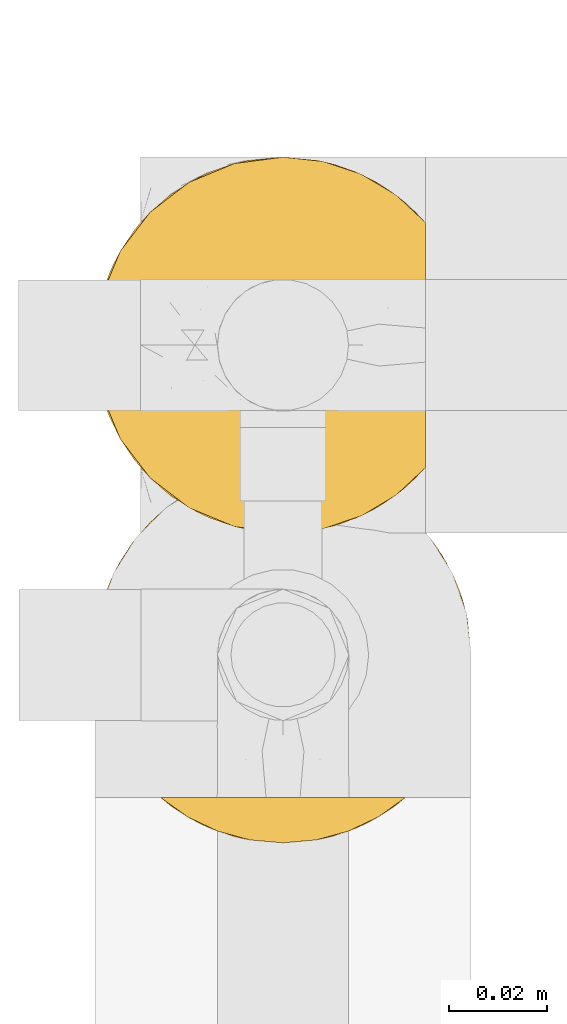
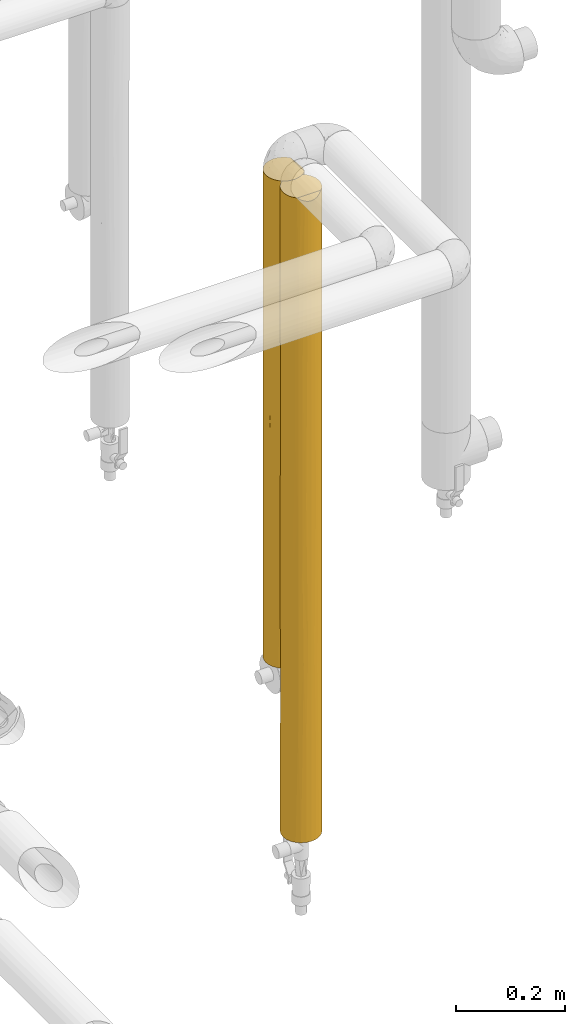
# One storey, part 30 of 827: 2 coverings.
"""IFC2X3 building model written with IfcOpenShell, lengths in millimetres."""

import ifcopenshell
import ifcopenshell.guid

model = None  # the IFC model being written
_history = None  # IfcOwnerHistory: only IFC2X3 demands one
_inside = {}  # id of a spatial element -> (the spatial element, [elements in it])
_under = {}  # id of a project, library or spatial element -> (it, [spatial elements below it])
_declared = {}  # id of a project -> (the project, [libraries it declares])
_typed = {}  # id of a type object -> (the type object, [elements of that type])
_made_of = {}  # id of a material, layer set ... -> (it, [elements and type objects made of it])


def new_model(schema):
    """Start an empty IFC model of exactly this schema.

    Asked for "IFC4X3", IfcOpenShell would pick the latest addendum, in which some entities
    have other attributes; the version numbers below select the first issue.
    IFC2X3 requires an IfcOwnerHistory on every rooted entity: one is made here for all.
    """
    global model, _history
    if schema == "IFC4X3":
        model = ifcopenshell.file(schema_version=(4, 3, 0, 0))
    else:
        model = ifcopenshell.file(schema=schema)
    _inside.clear()
    _under.clear()
    _declared.clear()
    _typed.clear()
    _made_of.clear()
    _history = None
    if model.schema == "IFC2X3":
        org = make("IfcOrganization", Name="unknown")
        user = make(
            "IfcPersonAndOrganization",
            ThePerson=make("IfcPerson", FamilyName="unknown"),
            TheOrganization=org,
        )
        app = make(
            "IfcApplication",
            ApplicationDeveloper=org,
            Version="unknown",
            ApplicationFullName="unknown",
            ApplicationIdentifier="unknown",
        )
        _history = make(
            "IfcOwnerHistory",
            OwningUser=user,
            OwningApplication=app,
            ChangeAction="ADDED",
            CreationDate=0,
        )
    return model


def make(cls, **values):
    """One entity of the class cls with the attributes given. An attribute that is None is left unset."""
    return model.create_entity(
        cls, **{name: value for name, value in values.items() if value is not None}
    )


def entity(cls, *values):
    """Any entity or typed value of the class cls, its attributes in the order of the schema. None: left unset."""
    e = model.create_entity(cls)
    for i, value in enumerate(values):
        if value is not None:
            e[i] = value
    return e


def rooted(cls, **values):
    """An entity with a GlobalId (a new one), such as an element, a storey or a relation."""
    return make(cls, GlobalId=ifcopenshell.guid.new(), OwnerHistory=_history, **values)


def si_unit(unit_type, name, prefix=None):
    """IfcSIUnit, for example si_unit("LENGTHUNIT", "METRE", prefix="MILLI")."""
    return make("IfcSIUnit", UnitType=unit_type, Prefix=prefix, Name=name)


def converted_unit(unit_type, name, factor, base, dimensions=None, offset=None):
    """IfcConversionBasedUnit, such as the inch: factor (a typed value) times the base unit."""
    return make(
        "IfcConversionBasedUnit"
        if offset is None
        else "IfcConversionBasedUnitWithOffset",
        ConversionOffset=offset,
        Dimensions=None
        if dimensions is None
        else entity("IfcDimensionalExponents", *dimensions),
        UnitType=unit_type,
        Name=name,
        ConversionFactor=make(
            "IfcMeasureWithUnit", ValueComponent=factor, UnitComponent=base
        ),
    )


def derived_unit(unit_type, elements):
    """IfcDerivedUnit: a product of units, each with its exponent."""
    return make(
        "IfcDerivedUnit",
        Elements=[
            make("IfcDerivedUnitElement", Unit=unit, Exponent=power)
            for unit, power in elements
        ],
        UnitType=unit_type,
    )


def assignment(units):
    """IfcUnitAssignment: the units of a project."""
    return None if units is None else make("IfcUnitAssignment", Units=units)


def point(xyz):
    """IfcCartesianPoint."""
    return None if xyz is None else make("IfcCartesianPoint", Coordinates=xyz)


def direction(xyz):
    """IfcDirection."""
    return None if xyz is None else make("IfcDirection", DirectionRatios=xyz)


def frame(location, z_axis=None, x_axis=None):
    """IfcAxis2Placement3D, a coordinate frame: its origin and axes. An axis left out is left unset."""
    return make(
        "IfcAxis2Placement3D",
        Location=point(location),
        Axis=direction(z_axis),
        RefDirection=direction(x_axis),
    )


def origin():
    """The frame at (0, 0, 0) with its axes left unset."""
    return frame((0.0, 0.0, 0.0))


def place(relative_to, where):
    """IfcLocalPlacement: puts the frame where relative to a parent placement (None: the world)."""
    return make(
        "IfcLocalPlacement", PlacementRelTo=relative_to, RelativePlacement=where
    )


def context(
    kind, dimensions, precision=None, world=None, true_north=None, identifier=None
):
    """IfcGeometricRepresentationContext, for example the 3D "Model" context."""
    return make(
        "IfcGeometricRepresentationContext",
        ContextIdentifier=identifier,
        ContextType=kind,
        CoordinateSpaceDimension=dimensions,
        Precision=precision,
        WorldCoordinateSystem=world,
        TrueNorth=true_north,
    )


def subcontext(parent, identifier, kind, view, scale=None):
    """IfcGeometricRepresentationSubContext, for example "Body" below "Model"."""
    return make(
        "IfcGeometricRepresentationSubContext",
        ContextIdentifier=identifier,
        ContextType=kind,
        ParentContext=parent,
        TargetScale=scale,
        TargetView=view,
    )


def project(units=None, contexts=None):
    """IfcProject with its units and contexts."""
    return rooted(
        "IfcProject",
        Name="project",
        RepresentationContexts=contexts,
        UnitsInContext=assignment(units),
    )


def spatial(cls, under=None, at=None, **own):
    """A site, building, storey or space (cls), placed at a placement, below another one or the project."""
    s = rooted(cls, ObjectPlacement=at, **own)
    if under is not None:
        _under.setdefault(under.id(), (under, []))[1].append(s)
    return s


def faces_of(points, faces, orient=None, outer=None):
    """IfcFace entities. A face is a list of loops; a loop is a list of indices into points, from 0.

    orient and outer hold one flag for each loop. By default every Orientation is true, the
    first loop of a face is its IfcFaceOuterBound and the others are IfcFaceBound.
    """
    made = []
    for i, loops in enumerate(faces):
        bounds = []
        for j, loop in enumerate(loops):
            is_outer = j == 0 if outer is None else outer[i][j]
            bounds.append(
                make(
                    "IfcFaceOuterBound" if is_outer else "IfcFaceBound",
                    Bound=make("IfcPolyLoop", Polygon=[points[k] for k in loop]),
                    Orientation=True if orient is None else orient[i][j],
                )
            )
        made.append(make("IfcFace", Bounds=bounds))
    return made


def faceted_brep(points, faces, orient=None, outer=None, voids=None):
    """IfcFacetedBrep: a solid bounded by flat faces; with voids (closed shells), ...WithVoids."""
    shared = [point(p) for p in points]
    hull = make("IfcClosedShell", CfsFaces=faces_of(shared, faces, orient, outer))
    if voids is None:
        return make("IfcFacetedBrep", Outer=hull)
    return make(
        "IfcFacetedBrepWithVoids",
        Outer=hull,
        Voids=[
            make(cls, CfsFaces=faces_of(shared, fs, o, b)) for cls, fs, o, b in voids
        ],
    )


def shape(context_of_items, identifier, shape_type, items):
    """IfcShapeRepresentation: the items that make up one representation, for example the "Body"."""
    return make(
        "IfcShapeRepresentation",
        ContextOfItems=context_of_items,
        RepresentationIdentifier=identifier,
        RepresentationType=shape_type,
        Items=items,
    )


def made_of(thing, what):
    """Note that an element or type object is made of a material, layer set ...; save() writes the relation."""
    if what is not None:
        _made_of.setdefault(what.id(), (what, []))[1].append(thing)
    return thing


def element(
    cls,
    number,
    at=None,
    inside=None,
    cuts=None,
    type_object=None,
    material=None,
    context=None,
    identifier="Body",
    shape_type=None,
    held_by="IfcProductDefinitionShape",
    body=None,
    shapes=None,
    **own,
):
    """One element of the class cls, such as IfcWall. Its Tag is "e" and its number.

    at: its placement. inside: the storey or other place that contains it. cuts: it is an
    opening in that element (IfcRelVoidsElement). A single representation is given by context,
    identifier, shape_type and body (its items); several are given by shapes. held_by: the class
    of the entity that holds the representations. save() writes the other relations.
    """
    e = rooted(cls, Tag="e%d" % number, ObjectPlacement=at, **own)
    if body is not None:
        shapes = [shape(context, identifier, shape_type, body)]
    if shapes is not None:
        e.Representation = make(held_by, Representations=shapes)
    if inside is not None:
        _inside.setdefault(inside.id(), (inside, []))[1].append(e)
    if cuts is not None:
        rooted(
            "IfcRelVoidsElement", RelatingBuildingElement=cuts, RelatedOpeningElement=e
        )
    if type_object is not None:
        _typed.setdefault(type_object.id(), (type_object, []))[1].append(e)
    return made_of(e, material)


def aggregate(whole, parts):
    """IfcRelAggregates: a whole, such as a stair, and the parts it consists of."""
    return rooted("IfcRelAggregates", RelatingObject=whole, RelatedObjects=parts)


def save(model, path):
    """Write the relations noted so far, then the file.

    IfcRelAggregates (storeys below a building ...), IfcRelContainedInSpatialStructure (elements
    in a storey), IfcRelDefinesByType, IfcRelAssociatesMaterial and IfcRelDeclares: one each for
    every whole, place, type object, material and project.
    """
    for whole, parts in _under.values():
        aggregate(whole, parts)
    for where, things in _inside.values():
        rooted(
            "IfcRelContainedInSpatialStructure",
            RelatedElements=things,
            RelatingStructure=where,
        )
    for kind, things in _typed.values():
        rooted("IfcRelDefinesByType", RelatedObjects=things, RelatingType=kind)
    for what, things in _made_of.values():
        rooted("IfcRelAssociatesMaterial", RelatedObjects=things, RelatingMaterial=what)
    for by, libraries in _declared.values():
        rooted("IfcRelDeclares", RelatingContext=by, RelatedDefinitions=libraries)
    model.write(path)


model = new_model("IFC2X3")

# Units and contexts
model_context = context("Model", 3, precision=0.01, world=origin(), true_north=direction((6.12303176911189e-17, 1.0)))
body_context = subcontext(model_context, "Body", "Model", "MODEL_VIEW")
ifc_project = project(units=[si_unit("LENGTHUNIT", "METRE", prefix="MILLI"), si_unit("AREAUNIT", "SQUARE_METRE"), si_unit("VOLUMEUNIT", "CUBIC_METRE"), converted_unit("PLANEANGLEUNIT", "DEGREE", entity("IfcRatioMeasure", 0.0174532925199433), si_unit("PLANEANGLEUNIT", "RADIAN"), dimensions=[0, 0, 0, 0, 0, 0, 0]), si_unit("MASSUNIT", "GRAM", prefix="KILO"), derived_unit("MASSDENSITYUNIT", [(si_unit("MASSUNIT", "GRAM", prefix="KILO"), 1), (si_unit("LENGTHUNIT", "METRE"), -3)]), derived_unit("MOMENTOFINERTIAUNIT", [(si_unit("LENGTHUNIT", "METRE"), 4)]), si_unit("TIMEUNIT", "SECOND"), si_unit("FREQUENCYUNIT", "HERTZ"), si_unit("THERMODYNAMICTEMPERATUREUNIT", "DEGREE_CELSIUS"), derived_unit("THERMALTRANSMITTANCEUNIT", [(si_unit("MASSUNIT", "GRAM", prefix="KILO"), 1), (si_unit("THERMODYNAMICTEMPERATUREUNIT", "KELVIN"), -1), (si_unit("TIMEUNIT", "SECOND"), -3)]), derived_unit("VOLUMETRICFLOWRATEUNIT", [(si_unit("LENGTHUNIT", "METRE"), 3), (si_unit("TIMEUNIT", "SECOND"), -1)]), derived_unit("MASSFLOWRATEUNIT", [(si_unit("MASSUNIT", "GRAM", prefix="KILO"), 1), (si_unit("TIMEUNIT", "SECOND"), -1)]), derived_unit("ROTATIONALFREQUENCYUNIT", [(si_unit("TIMEUNIT", "SECOND"), -1)]), si_unit("ELECTRICCURRENTUNIT", "AMPERE"), si_unit("ELECTRICVOLTAGEUNIT", "VOLT"), si_unit("POWERUNIT", "WATT"), si_unit("FORCEUNIT", "NEWTON", prefix="KILO"), si_unit("ILLUMINANCEUNIT", "LUX"), si_unit("LUMINOUSFLUXUNIT", "LUMEN"), si_unit("LUMINOUSINTENSITYUNIT", "CANDELA"), derived_unit("USERDEFINED", [(si_unit("MASSUNIT", "GRAM", prefix="KILO"), -1), (si_unit("LENGTHUNIT", "METRE"), -2), (si_unit("TIMEUNIT", "SECOND"), 3), (si_unit("LUMINOUSFLUXUNIT", "LUMEN"), 1)]), derived_unit("LINEARVELOCITYUNIT", [(si_unit("LENGTHUNIT", "METRE"), 1), (si_unit("TIMEUNIT", "SECOND"), -1)]), si_unit("PRESSUREUNIT", "PASCAL"), derived_unit("USERDEFINED", [(si_unit("LENGTHUNIT", "METRE"), -2), (si_unit("MASSUNIT", "GRAM", prefix="KILO"), 1), (si_unit("TIMEUNIT", "SECOND"), -2)]), derived_unit("LINEARFORCEUNIT", [(si_unit("MASSUNIT", "GRAM", prefix="KILO"), 1), (si_unit("LENGTHUNIT", "METRE"), 1), (si_unit("TIMEUNIT", "SECOND"), -2), (si_unit("LENGTHUNIT", "METRE"), -1)]), derived_unit("PLANARFORCEUNIT", [(si_unit("MASSUNIT", "GRAM", prefix="KILO"), 1), (si_unit("LENGTHUNIT", "METRE"), 1), (si_unit("TIMEUNIT", "SECOND"), -2), (si_unit("LENGTHUNIT", "METRE"), -2)])], contexts=[model_context])

# Site, building, storey
site_placement = place(None, origin())
site = spatial("IfcSite", under=ifc_project, at=site_placement, CompositionType="ELEMENT")
building_placement = place(site_placement, origin())
building = spatial("IfcBuilding", under=site, at=building_placement, CompositionType="ELEMENT")
storey_placement = place(building_placement, frame((0.0, 0.0, 28200.0)))
storey = spatial("IfcBuildingStorey", under=building, at=storey_placement, Name="08", CompositionType="ELEMENT", Elevation=28200.0)

# Coverings
covering_1_placement = place(storey_placement, frame((18846.14, 12179.52, 779.1)))
element("IfcCovering", 1, at=covering_1_placement, inside=storey, Name=":ADSK_", ObjectType=":ADSK_", PredefinedType="INSULATION", context=body_context, shape_type="Brep", body=[
    faceted_brep([(63.08, 9.31, 1091.8), (69.1, 14.94, 1091.8), (69.1, 65.05, 1091.8), (63.08, 70.68, 1091.8), (56.01, 74.9, 1091.8), (48.2, 77.51, 1091.8), (40.0, 78.4, 1091.8), (30.06, 77.09, 1091.8), (20.8, 73.25, 1091.8), (12.84, 67.15, 1091.8), (6.74, 59.2, 1091.8), (2.9, 49.93, 1091.8), (1.6, 40.0, 1091.8), (2.9, 30.06, 1091.8), (6.74, 20.8, 1091.8), (12.84, 12.84, 1091.8), (20.8, 6.74, 1091.8), (30.06, 2.9, 1091.8), (40.0, 1.6, 1091.8), (48.2, 2.48, 1091.8), (56.01, 5.09, 1091.8), (59.2, 6.74, 0.0), (49.93, 2.9, 0.0), (40.0, 1.6, 0.0), (30.06, 2.9, 0.0), (20.8, 6.74, 0.0), (12.84, 12.84, 0.0), (6.74, 20.8, 0.0), (2.9, 30.06, 0.0), (1.6, 40.0, 0.0), (2.9, 49.93, 0.0), (6.74, 59.2, 0.0), (12.84, 67.15, 0.0), (20.8, 73.25, 0.0), (30.06, 77.09, 0.0), (40.0, 78.4, 0.0), (49.93, 77.09, 0.0), (59.2, 73.25, 0.0), (67.15, 67.15, 0.0), (73.25, 59.2, 0.0), (77.09, 49.93, 0.0), (78.4, 40.0, 0.0), (77.09, 30.06, 0.0), (73.25, 20.8, 0.0), (67.15, 12.84, 0.0), (16.62, 70.46, 253.73), (25.3, 75.47, 761.2), (29.25, 76.86, 559.5), (22.76, 74.31, 435.59), (23.2, 74.53, 210.94), (29.5, 76.93, 324.56), (40.0, 78.4, 216.37), (16.62, 70.46, 838.07), (2.28, 47.19, 324.56), (2.23, 46.96, 566.86), (4.52, 54.69, 634.93), (40.0, 78.4, 875.43), (40.0, 78.4, 432.75), (16.62, 70.46, 545.9), (9.53, 63.37, 330.6), (1.6, 40.0, 432.75), (9.53, 63.37, 794.48), (32.96, 77.75, 767.24), (40.0, 78.4, 659.05), (5.29, 56.43, 868.98), (2.6, 48.72, 822.18), (4.52, 54.69, 260.5), (10.67, 64.79, 562.54), (1.6, 40.0, 216.37), (1.6, 40.0, 659.05), (1.6, 40.0, 762.27), (1.6, 40.0, 875.43), (31.28, 2.6, 822.18), (9.53, 16.62, 840.76), (3.54, 27.94, 545.9), (2.28, 32.8, 767.24), (2.28, 32.8, 324.56), (4.52, 25.3, 259.78), (9.53, 16.62, 251.04), (4.52, 25.3, 832.02), (16.62, 9.53, 330.6), (15.2, 10.67, 562.54), (9.53, 16.62, 545.9), (32.8, 2.28, 324.56), (40.0, 1.6, 432.75), (33.03, 2.23, 566.86), (23.57, 5.29, 868.98), (25.3, 4.52, 634.93), (16.62, 9.53, 794.48), (40.0, 1.6, 216.37), (25.3, 4.52, 260.5), (40.0, 1.6, 659.05), (40.0, 1.6, 762.27), (40.0, 1.6, 875.43), (63.37, 9.53, 322.05), (70.46, 16.62, 252.65), (75.47, 25.3, 316.65), (70.98, 17.31, 542.8), (65.6, 11.38, 768.94), (71.1, 17.47, 825.15), (59.66, 7.01, 887.24), (52.17, 3.58, 828.36), (59.66, 7.01, 650.63), (76.74, 28.83, 534.48), (74.39, 22.92, 678.74), (65.29, 11.1, 539.94), (54.69, 4.52, 258.75), (47.2, 2.28, 324.56), (50.14, 2.96, 545.9), (58.19, 6.18, 441.76), (78.4, 40.0, 866.13), (77.79, 33.21, 1083.1), (77.01, 29.79, 775.91), (76.0, 26.63, 1084.9), (78.4, 40.0, 649.75), (73.07, 20.48, 1087.83), (74.87, 23.92, 889.43), (78.4, 40.0, 1082.5), (78.4, 40.0, 432.75), (77.75, 32.96, 324.56), (78.4, 40.0, 216.37), (76.74, 51.16, 534.48), (54.69, 75.47, 328.95), (47.03, 77.75, 324.56), (50.79, 76.85, 532.17), (75.47, 54.69, 316.65), (59.66, 72.98, 650.63), (65.6, 68.61, 768.94), (65.42, 68.77, 530.69), (77.01, 50.2, 775.91), (76.0, 53.36, 1084.9), (77.79, 46.78, 1083.1), (74.39, 57.07, 678.74), (63.37, 70.46, 260.15), (74.7, 56.44, 892.73), (70.46, 63.37, 251.05), (71.1, 62.52, 825.15), (73.07, 59.51, 1087.83), (50.25, 77.0, 767.24), (70.98, 62.68, 542.8), (59.66, 72.98, 887.24), (77.75, 47.03, 324.56)], [[[0, 1, 2, 3, 4, 5, 6, 7, 8, 9, 10, 11, 12, 13, 14, 15, 16, 17, 18, 19, 20]], [[21, 22, 23, 24, 25, 26, 27, 28, 29, 30, 31, 32, 33, 34, 35, 36, 37, 38, 39, 40, 41, 42, 43, 44]], [[33, 32, 45]], [[46, 47, 48]], [[49, 34, 33]], [[50, 51, 34]], [[8, 52, 9]], [[53, 54, 55]], [[51, 35, 34]], [[7, 6, 56]], [[50, 57, 51]], [[47, 57, 50]], [[49, 45, 48]], [[46, 8, 7]], [[58, 45, 59]], [[53, 60, 54]], [[61, 10, 9]], [[62, 56, 63]], [[64, 55, 65]], [[32, 31, 59]], [[59, 31, 66]], [[61, 55, 64]], [[54, 65, 55]], [[58, 52, 46]], [[67, 55, 61]], [[60, 53, 68]], [[46, 62, 47]], [[66, 31, 30]], [[52, 61, 9]], [[11, 65, 12]], [[59, 67, 58]], [[68, 53, 30]], [[55, 59, 66]], [[59, 45, 32]], [[45, 58, 48]], [[46, 52, 8]], [[52, 58, 67]], [[30, 29, 68]], [[55, 66, 53]], [[30, 53, 66]], [[54, 60, 69, 70]], [[65, 54, 70]], [[65, 70, 71, 12]], [[64, 11, 10]], [[11, 64, 65]], [[61, 64, 10]], [[63, 57, 47]], [[56, 62, 7]], [[7, 62, 46]], [[47, 62, 63]], [[48, 47, 50]], [[48, 50, 49]], [[46, 48, 58]], [[34, 49, 50]], [[45, 49, 33]], [[55, 67, 59]], [[52, 67, 61]], [[29, 28, 68]], [[13, 12, 71]], [[17, 72, 18]], [[73, 15, 14]], [[74, 75, 69]], [[76, 60, 68]], [[75, 71, 70, 69]], [[28, 27, 77]], [[77, 27, 78]], [[14, 79, 73]], [[14, 13, 79]], [[25, 80, 26]], [[80, 81, 82]], [[83, 84, 85]], [[81, 73, 82]], [[69, 60, 74]], [[86, 87, 72]], [[87, 86, 88]], [[88, 16, 15]], [[82, 78, 80]], [[84, 83, 89]], [[85, 72, 87]], [[90, 80, 25]], [[77, 82, 74]], [[90, 25, 24]], [[81, 87, 88]], [[83, 85, 87]], [[27, 26, 78]], [[74, 60, 76]], [[71, 75, 13]], [[82, 79, 74]], [[89, 83, 24]], [[87, 80, 90]], [[80, 78, 26]], [[82, 77, 78]], [[82, 73, 79]], [[88, 15, 73]], [[74, 79, 75]], [[13, 75, 79]], [[24, 23, 89]], [[87, 90, 83]], [[24, 83, 90]], [[85, 84, 91, 92]], [[72, 85, 92]], [[72, 92, 93, 18]], [[86, 17, 16]], [[17, 86, 72]], [[88, 86, 16]], [[76, 28, 77]], [[28, 76, 68]], [[74, 76, 77]], [[87, 81, 80]], [[73, 81, 88]], [[94, 21, 44]], [[95, 96, 97]], [[98, 97, 99]], [[100, 101, 102]], [[96, 103, 104]], [[102, 105, 98]], [[23, 22, 89]], [[94, 106, 21]], [[89, 107, 84]], [[19, 93, 101]], [[101, 20, 19]], [[108, 101, 91]], [[100, 0, 20]], [[109, 108, 106]], [[100, 98, 0]], [[106, 22, 21]], [[1, 0, 98]], [[110, 111, 112]], [[97, 96, 104]], [[111, 113, 112]], [[114, 112, 103]], [[1, 99, 115]], [[112, 116, 104]], [[117, 111, 110]], [[118, 119, 120]], [[44, 43, 95]], [[94, 44, 95]], [[96, 43, 42]], [[91, 84, 108]], [[116, 115, 99]], [[105, 109, 94]], [[102, 101, 108]], [[42, 120, 119]], [[96, 119, 103]], [[109, 106, 94]], [[108, 84, 107]], [[96, 95, 43]], [[95, 97, 105]], [[101, 100, 20]], [[98, 100, 102]], [[109, 105, 102]], [[98, 99, 1]], [[95, 105, 94]], [[97, 98, 105]], [[107, 22, 106]], [[22, 107, 89]], [[108, 107, 106]], [[42, 41, 120]], [[118, 114, 103]], [[42, 119, 96]], [[103, 119, 118]], [[103, 112, 104]], [[116, 112, 113]], [[99, 97, 104]], [[115, 116, 113]], [[99, 104, 116]], [[112, 114, 110]], [[93, 19, 18]], [[101, 93, 92, 91]], [[108, 109, 102]], [[114, 118, 121]], [[122, 123, 124]], [[40, 39, 125]], [[126, 122, 124]], [[127, 128, 126]], [[129, 130, 131]], [[132, 121, 125]], [[122, 133, 37]], [[132, 134, 129]], [[133, 135, 38]], [[131, 110, 129]], [[136, 2, 137]], [[2, 136, 127]], [[57, 123, 51]], [[56, 138, 63]], [[124, 63, 138]], [[139, 128, 127]], [[4, 140, 138]], [[38, 37, 133]], [[56, 6, 5]], [[36, 122, 37]], [[121, 132, 129]], [[140, 4, 3]], [[36, 51, 123]], [[141, 40, 125]], [[137, 130, 134]], [[140, 127, 126]], [[4, 138, 5]], [[56, 5, 138]], [[135, 125, 39]], [[141, 121, 118]], [[40, 120, 41]], [[128, 122, 126]], [[38, 135, 39]], [[128, 135, 133]], [[125, 135, 139]], [[3, 2, 127]], [[138, 140, 126]], [[3, 127, 140]], [[139, 127, 136]], [[135, 128, 139]], [[122, 128, 133]], [[36, 35, 51]], [[57, 63, 124]], [[36, 123, 122]], [[124, 123, 57]], [[126, 124, 138]], [[40, 141, 120]], [[118, 120, 141]], [[121, 141, 125]], [[132, 125, 139]], [[114, 121, 129]], [[139, 136, 132]], [[134, 132, 136]], [[137, 134, 136]], [[129, 134, 130]], [[110, 131, 117]], [[110, 114, 129]], [[1, 115, 113, 111, 117, 131, 130, 137, 2]]]),
])
covering_2_placement = place(storey_placement, frame((18846.14, 12116.18, 426.5)))
element("IfcCovering", 2, at=covering_2_placement, inside=storey, Name=":ADSK_", ObjectType=":ADSK_", PredefinedType="INSULATION", context=body_context, shape_type="Brep", body=[
    faceted_brep([(74.9, 23.98, 1444.4), (77.51, 31.79, 1444.4), (78.4, 40.0, 1444.4), (77.09, 49.93, 1444.4), (73.25, 59.2, 1444.4), (67.15, 67.15, 1444.4), (59.2, 73.25, 1444.4), (49.93, 77.09, 1444.4), (40.0, 78.4, 1444.4), (30.06, 77.09, 1444.4), (20.8, 73.25, 1444.4), (12.84, 67.15, 1444.4), (6.74, 59.2, 1444.4), (2.9, 49.93, 1444.4), (1.6, 40.0, 1444.4), (2.48, 31.79, 1444.4), (5.09, 23.98, 1444.4), (9.31, 16.91, 1444.4), (14.94, 10.9, 1444.4), (65.05, 10.9, 1444.4), (70.68, 16.91, 1444.4), (59.2, 6.74, 0.0), (49.93, 2.9, 0.0), (40.0, 1.6, 0.0), (30.06, 2.9, 0.0), (20.8, 6.74, 0.0), (12.84, 12.84, 0.0), (6.74, 20.8, 0.0), (2.9, 30.06, 0.0), (1.6, 40.0, 0.0), (2.9, 49.93, 0.0), (6.74, 59.2, 0.0), (12.84, 67.15, 0.0), (20.8, 73.25, 0.0), (30.06, 77.09, 0.0), (40.0, 78.4, 0.0), (49.93, 77.09, 0.0), (59.2, 73.25, 0.0), (67.15, 67.15, 0.0), (73.25, 59.2, 0.0), (77.09, 49.93, 0.0), (78.4, 40.0, 0.0), (77.09, 30.06, 0.0), (73.25, 20.8, 0.0), (67.15, 12.84, 0.0), (4.52, 25.3, 193.07), (2.37, 32.3, 313.75), (31.75, 2.49, 1110.54), (29.53, 3.05, 757.93), (40.0, 1.6, 1002.35), (9.53, 16.62, 289.66), (4.52, 25.3, 434.43), (40.0, 1.6, 284.8), (29.95, 2.93, 224.82), (7.01, 20.33, 1227.34), (7.01, 20.33, 960.82), (11.96, 13.75, 1158.75), (16.78, 9.41, 1039.14), (12.26, 13.43, 901.86), (3.58, 27.82, 1158.76), (4.37, 25.65, 656.31), (2.85, 30.25, 829.18), (2.43, 32.05, 546.4), (16.62, 9.53, 253.48), (40.0, 1.6, 1218.73), (40.0, 1.6, 1435.1), (33.21, 2.2, 1435.7), (9.28, 16.95, 628.01), (26.63, 4.0, 1437.5), (23.31, 5.41, 1061.0), (22.88, 5.62, 839.94), (22.99, 5.57, 613.56), (17.51, 8.86, 1251.94), (1.6, 40.0, 1228.03), (23.12, 5.5, 198.43), (20.48, 6.92, 1440.43), (40.0, 1.6, 569.61), (40.0, 1.6, 785.98), (16.96, 9.27, 491.07), (33.27, 2.19, 427.21), (1.6, 40.0, 1011.65), (1.6, 40.0, 578.91), (1.6, 40.0, 432.74), (1.6, 40.0, 216.37), (1.6, 40.0, 795.28), (1.6, 40.0, 649.12), (17.22, 9.08, 728.81), (25.3, 4.52, 399.33), (1.6, 40.0, 865.49), (70.46, 16.62, 289.66), (63.37, 9.53, 253.48), (63.21, 9.41, 1039.14), (62.77, 9.08, 728.81), (67.73, 13.43, 901.86), (46.72, 2.19, 427.21), (50.04, 2.93, 224.82), (54.69, 4.52, 399.33), (62.48, 8.86, 1251.94), (59.51, 6.92, 1440.43), (56.68, 5.41, 1061.0), (56.87, 5.5, 198.43), (53.36, 4.0, 1437.5), (75.47, 25.3, 193.07), (48.24, 2.49, 1110.54), (46.78, 2.2, 1435.7), (68.03, 13.75, 1158.75), (76.41, 27.82, 1158.76), (78.4, 40.0, 1228.03), (50.46, 3.05, 757.93), (62.51, 8.89, 490.22), (70.71, 16.95, 628.01), (77.62, 32.3, 313.75), (75.47, 25.3, 434.43), (77.57, 32.05, 546.4), (72.98, 20.33, 1227.34), (72.98, 20.33, 960.82), (77.14, 30.25, 829.18), (78.4, 40.0, 1011.65), (57.23, 5.68, 842.31), (56.61, 5.38, 623.79), (78.4, 40.0, 578.91), (78.4, 40.0, 216.37), (75.62, 25.65, 656.31), (78.4, 40.0, 795.28), (78.4, 40.0, 289.45), (70.46, 63.37, 259.19), (63.37, 70.46, 324.27), (77.57, 47.93, 822.06), (77.7, 47.28, 1119.84), (76.11, 53.05, 1249.85), (54.69, 75.47, 245.05), (77.06, 50.04, 593.97), (77.72, 47.17, 382.64), (75.47, 54.69, 404.68), (40.0, 78.4, 216.38), (40.0, 78.4, 1228.03), (75.47, 54.69, 1039.72), (63.37, 70.46, 1154.74), (47.29, 77.7, 955.06), (49.28, 77.26, 1196.58), (54.69, 75.47, 1009.97), (76.61, 51.58, 210.62), (62.1, 71.39, 567.18), (68.22, 66.03, 490.7), (47.28, 77.7, 324.56), (54.69, 75.47, 529.72), (46.88, 77.77, 561.65), (51.85, 76.52, 769.84), (56.67, 74.59, 1230.51), (70.46, 63.37, 1190.92), (62.86, 70.84, 829.17), (71.72, 61.63, 956.56), (74.95, 55.9, 747.81), (72.7, 60.11, 535.41), (70.46, 63.37, 722.2), (40.0, 78.4, 289.46), (40.0, 78.4, 432.75), (40.0, 78.4, 649.12), (40.0, 78.4, 795.28), (40.0, 78.4, 865.49), (40.0, 78.4, 578.91), (40.0, 78.4, 1011.65), (16.62, 70.46, 259.19), (9.53, 63.37, 324.27), (32.06, 77.57, 822.06), (32.71, 77.7, 1119.84), (26.94, 76.11, 1249.85), (4.52, 54.69, 245.05), (29.95, 77.06, 593.97), (32.83, 77.72, 382.64), (25.3, 75.47, 404.68), (25.3, 75.47, 1039.72), (9.53, 63.37, 1154.74), (2.29, 47.29, 955.06), (2.74, 49.28, 1196.58), (4.52, 54.69, 1009.97), (28.41, 76.61, 210.62), (8.6, 62.1, 567.18), (13.96, 68.22, 490.7), (2.29, 47.28, 324.56), (4.52, 54.69, 529.72), (2.22, 46.88, 561.65), (3.47, 51.85, 769.84), (5.4, 56.67, 1230.51), (16.62, 70.46, 1190.92), (9.15, 62.86, 829.17), (18.36, 71.72, 956.56), (24.09, 74.95, 747.81), (19.88, 72.7, 535.41), (16.62, 70.46, 722.2)], [[[0, 1, 2, 3, 4, 5, 6, 7, 8, 9, 10, 11, 12, 13, 14, 15, 16, 17, 18, 19, 20]], [[21, 22, 23, 24, 25, 26, 27, 28, 29, 30, 31, 32, 33, 34, 35, 36, 37, 38, 39, 40, 41, 42, 43, 44]], [[28, 45, 46]], [[47, 48, 49]], [[45, 50, 51]], [[52, 53, 23]], [[54, 55, 56]], [[57, 56, 58]], [[59, 16, 15]], [[27, 45, 28]], [[60, 61, 62]], [[58, 56, 55]], [[26, 25, 63]], [[27, 26, 50]], [[56, 17, 54]], [[64, 65, 66]], [[59, 54, 16]], [[50, 67, 51]], [[47, 68, 69]], [[66, 68, 47]], [[48, 70, 71]], [[57, 72, 56]], [[15, 14, 73]], [[53, 74, 24]], [[50, 26, 63]], [[17, 56, 18]], [[72, 68, 75]], [[55, 59, 61]], [[49, 48, 76, 77]], [[50, 78, 67]], [[49, 64, 47]], [[79, 53, 52]], [[72, 75, 18]], [[59, 73, 80]], [[61, 59, 80]], [[66, 47, 64]], [[47, 69, 48]], [[70, 48, 69]], [[48, 71, 79]], [[46, 81, 82, 83]], [[83, 29, 28]], [[63, 78, 50]], [[62, 84, 85, 81]], [[62, 81, 46]], [[58, 67, 86]], [[76, 79, 52]], [[60, 55, 61]], [[74, 63, 25]], [[15, 73, 59]], [[87, 71, 78]], [[48, 79, 76]], [[53, 79, 87]], [[74, 53, 87]], [[53, 24, 23]], [[63, 74, 87]], [[24, 74, 25]], [[50, 45, 27]], [[46, 45, 51]], [[46, 51, 62]], [[28, 46, 83]], [[60, 62, 51]], [[62, 61, 84]], [[51, 67, 60]], [[55, 60, 67]], [[67, 58, 55]], [[86, 70, 57]], [[86, 57, 58]], [[69, 68, 72]], [[56, 72, 18]], [[69, 72, 57]], [[16, 54, 17]], [[55, 54, 59]], [[57, 70, 69]], [[71, 70, 86]], [[78, 71, 86]], [[71, 87, 79]], [[67, 78, 86]], [[87, 78, 63]], [[61, 80, 88, 84]], [[44, 89, 90]], [[91, 92, 93]], [[94, 76, 52]], [[95, 96, 94]], [[97, 19, 98]], [[97, 99, 91]], [[95, 100, 96]], [[101, 99, 97]], [[102, 89, 43]], [[64, 103, 104]], [[21, 44, 90]], [[19, 105, 20]], [[103, 64, 49]], [[106, 107, 1]], [[108, 99, 103]], [[92, 109, 110]], [[111, 112, 102]], [[109, 96, 90]], [[112, 111, 113]], [[105, 114, 20]], [[105, 93, 115]], [[114, 0, 20]], [[0, 106, 1]], [[42, 102, 43]], [[116, 117, 106]], [[43, 89, 44]], [[101, 104, 103]], [[115, 106, 114]], [[118, 108, 119]], [[120, 113, 111]], [[116, 106, 115]], [[1, 107, 2]], [[104, 65, 64]], [[108, 49, 77, 76]], [[103, 99, 101]], [[94, 108, 76]], [[108, 94, 119]], [[42, 41, 121]], [[110, 89, 112]], [[92, 119, 109]], [[115, 110, 122]], [[113, 123, 116]], [[122, 112, 113]], [[22, 95, 23]], [[93, 110, 115]], [[89, 110, 109]], [[117, 107, 106]], [[100, 90, 96]], [[52, 23, 95]], [[94, 96, 119]], [[52, 95, 94]], [[100, 22, 21]], [[22, 100, 95]], [[90, 100, 21]], [[111, 42, 121]], [[89, 102, 112]], [[42, 111, 102]], [[111, 121, 124, 120]], [[122, 113, 116]], [[115, 122, 116]], [[110, 112, 122]], [[91, 93, 105]], [[110, 93, 92]], [[105, 19, 97]], [[91, 99, 118]], [[97, 98, 101]], [[105, 97, 91]], [[115, 114, 105]], [[0, 114, 106]], [[49, 108, 103]], [[118, 119, 92]], [[96, 109, 119]], [[109, 90, 89]], [[91, 118, 92]], [[108, 118, 99]], [[123, 113, 120]], [[123, 117, 116]], [[125, 38, 126]], [[127, 117, 123, 120]], [[3, 107, 128]], [[128, 129, 3]], [[126, 37, 130]], [[131, 132, 133]], [[36, 35, 134]], [[8, 7, 135]], [[127, 136, 128]], [[6, 5, 137]], [[138, 139, 140]], [[141, 39, 125]], [[126, 142, 143]], [[130, 144, 145]], [[146, 147, 145]], [[117, 128, 107]], [[148, 140, 139]], [[149, 137, 5]], [[37, 36, 130]], [[37, 126, 38]], [[137, 140, 148]], [[140, 137, 150]], [[137, 151, 150]], [[152, 136, 127]], [[141, 133, 132]], [[38, 125, 39]], [[145, 144, 146]], [[153, 125, 143]], [[5, 4, 149]], [[138, 140, 147]], [[149, 151, 137]], [[143, 125, 126]], [[40, 124, 121, 41]], [[3, 2, 107]], [[141, 125, 133]], [[129, 149, 4]], [[151, 149, 136]], [[154, 143, 142]], [[150, 142, 147]], [[134, 144, 36]], [[126, 130, 145]], [[144, 134, 155, 156]], [[144, 156, 146]], [[36, 144, 130]], [[147, 157, 158, 159]], [[159, 138, 147]], [[146, 157, 147]], [[150, 147, 140]], [[146, 156, 160, 157]], [[127, 128, 117]], [[128, 136, 129]], [[153, 131, 133]], [[153, 152, 131]], [[149, 129, 136]], [[4, 3, 129]], [[138, 159, 161, 135]], [[139, 135, 7]], [[135, 139, 138]], [[148, 7, 6]], [[7, 148, 139]], [[137, 148, 6]], [[126, 145, 142]], [[153, 143, 154]], [[147, 142, 145]], [[154, 142, 150]], [[152, 153, 154]], [[125, 153, 133]], [[152, 154, 151]], [[152, 127, 131]], [[127, 120, 131]], [[132, 120, 124]], [[120, 132, 131]], [[141, 124, 40]], [[124, 141, 132]], [[39, 141, 40]], [[152, 151, 136]], [[150, 151, 154]], [[162, 32, 163]], [[164, 161, 159, 158, 157, 160]], [[9, 135, 165]], [[165, 166, 9]], [[163, 31, 167]], [[168, 169, 170]], [[30, 29, 83]], [[14, 13, 73]], [[164, 171, 165]], [[12, 11, 172]], [[173, 174, 175]], [[176, 33, 162]], [[163, 177, 178]], [[167, 179, 180]], [[181, 182, 180]], [[161, 165, 135]], [[183, 175, 174]], [[184, 172, 11]], [[31, 30, 167]], [[31, 163, 32]], [[172, 175, 183]], [[175, 172, 185]], [[172, 186, 185]], [[187, 171, 164]], [[176, 170, 169]], [[32, 162, 33]], [[180, 179, 181]], [[188, 162, 178]], [[11, 10, 184]], [[173, 175, 182]], [[184, 186, 172]], [[178, 162, 163]], [[34, 155, 134, 35]], [[9, 8, 135]], [[176, 162, 170]], [[166, 184, 10]], [[186, 184, 171]], [[189, 178, 177]], [[185, 177, 182]], [[83, 179, 30]], [[163, 167, 180]], [[179, 83, 82]], [[179, 82, 181]], [[30, 179, 167]], [[182, 85, 84, 88]], [[88, 173, 182]], [[181, 85, 182]], [[185, 182, 175]], [[181, 82, 81, 85]], [[164, 165, 161]], [[165, 171, 166]], [[188, 168, 170]], [[188, 187, 168]], [[184, 166, 171]], [[10, 9, 166]], [[173, 88, 80, 73]], [[174, 73, 13]], [[73, 174, 173]], [[183, 13, 12]], [[13, 183, 174]], [[172, 183, 12]], [[163, 180, 177]], [[188, 178, 189]], [[182, 177, 180]], [[189, 177, 185]], [[187, 188, 189]], [[162, 188, 170]], [[187, 189, 186]], [[187, 164, 168]], [[164, 160, 168]], [[169, 160, 156, 155]], [[160, 169, 168]], [[176, 155, 34]], [[155, 176, 169]], [[33, 176, 34]], [[187, 186, 171]], [[185, 186, 189]], [[75, 68, 66, 65, 104, 101, 98, 19, 18]]]),
])

save(model, "model.ifc")
